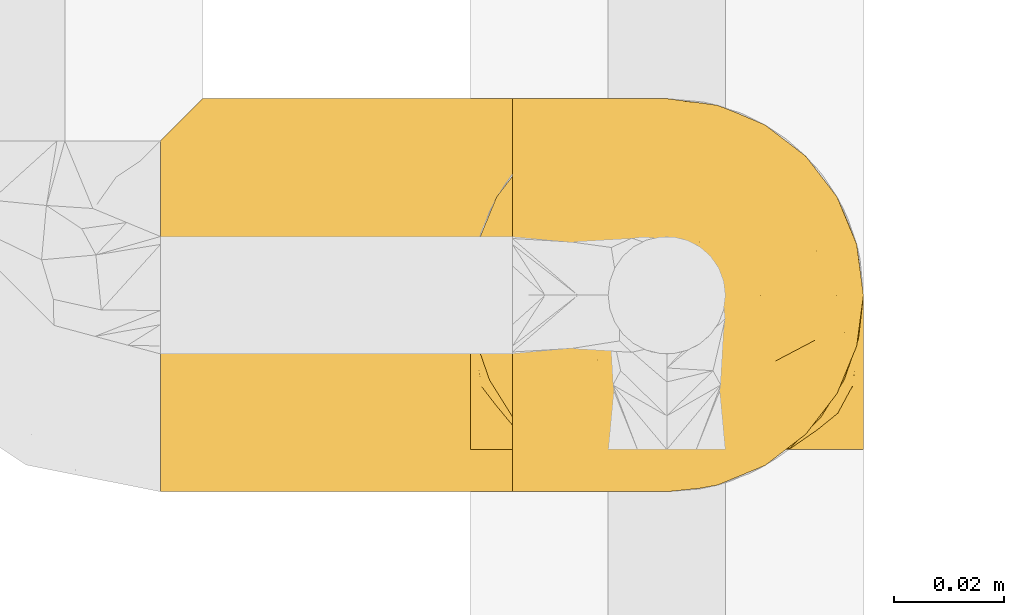
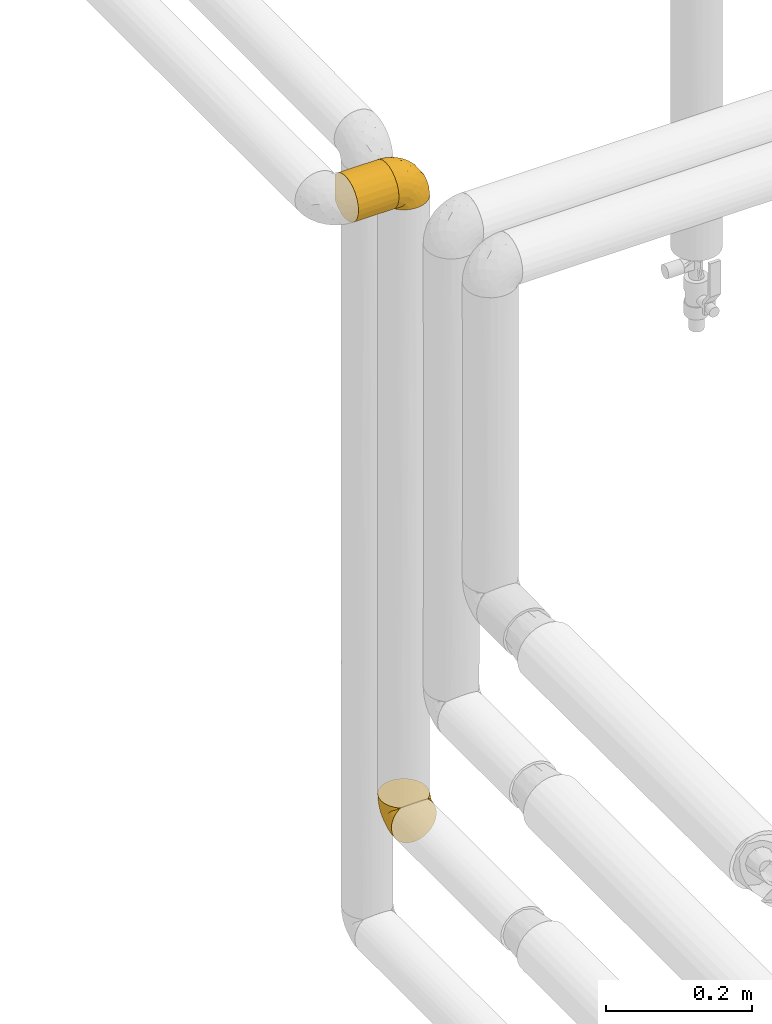
# One storey, part 79 of 827: 3 coverings.
"""IFC2X3 building model written with IfcOpenShell, lengths in millimetres."""

from ifc_helpers import new_model, entity, si_unit, converted_unit, derived_unit, direction, frame, origin, place, context, subcontext, project, spatial, faceted_brep, element, save


model = new_model("IFC2X3")

# Units and contexts
model_context = context("Model", 3, precision=0.01, world=origin(), true_north=direction((6.12303176911189e-17, 1.0)))
body_context = subcontext(model_context, "Body", "Model", "MODEL_VIEW")
ifc_project = project(units=[si_unit("LENGTHUNIT", "METRE", prefix="MILLI"), si_unit("AREAUNIT", "SQUARE_METRE"), si_unit("VOLUMEUNIT", "CUBIC_METRE"), converted_unit("PLANEANGLEUNIT", "DEGREE", entity("IfcRatioMeasure", 0.0174532925199433), si_unit("PLANEANGLEUNIT", "RADIAN"), dimensions=[0, 0, 0, 0, 0, 0, 0]), si_unit("MASSUNIT", "GRAM", prefix="KILO"), derived_unit("MASSDENSITYUNIT", [(si_unit("MASSUNIT", "GRAM", prefix="KILO"), 1), (si_unit("LENGTHUNIT", "METRE"), -3)]), derived_unit("MOMENTOFINERTIAUNIT", [(si_unit("LENGTHUNIT", "METRE"), 4)]), si_unit("TIMEUNIT", "SECOND"), si_unit("FREQUENCYUNIT", "HERTZ"), si_unit("THERMODYNAMICTEMPERATUREUNIT", "DEGREE_CELSIUS"), derived_unit("THERMALTRANSMITTANCEUNIT", [(si_unit("MASSUNIT", "GRAM", prefix="KILO"), 1), (si_unit("THERMODYNAMICTEMPERATUREUNIT", "KELVIN"), -1), (si_unit("TIMEUNIT", "SECOND"), -3)]), derived_unit("VOLUMETRICFLOWRATEUNIT", [(si_unit("LENGTHUNIT", "METRE"), 3), (si_unit("TIMEUNIT", "SECOND"), -1)]), derived_unit("MASSFLOWRATEUNIT", [(si_unit("MASSUNIT", "GRAM", prefix="KILO"), 1), (si_unit("TIMEUNIT", "SECOND"), -1)]), derived_unit("ROTATIONALFREQUENCYUNIT", [(si_unit("TIMEUNIT", "SECOND"), -1)]), si_unit("ELECTRICCURRENTUNIT", "AMPERE"), si_unit("ELECTRICVOLTAGEUNIT", "VOLT"), si_unit("POWERUNIT", "WATT"), si_unit("FORCEUNIT", "NEWTON", prefix="KILO"), si_unit("ILLUMINANCEUNIT", "LUX"), si_unit("LUMINOUSFLUXUNIT", "LUMEN"), si_unit("LUMINOUSINTENSITYUNIT", "CANDELA"), derived_unit("USERDEFINED", [(si_unit("MASSUNIT", "GRAM", prefix="KILO"), -1), (si_unit("LENGTHUNIT", "METRE"), -2), (si_unit("TIMEUNIT", "SECOND"), 3), (si_unit("LUMINOUSFLUXUNIT", "LUMEN"), 1)]), derived_unit("LINEARVELOCITYUNIT", [(si_unit("LENGTHUNIT", "METRE"), 1), (si_unit("TIMEUNIT", "SECOND"), -1)]), si_unit("PRESSUREUNIT", "PASCAL"), derived_unit("USERDEFINED", [(si_unit("LENGTHUNIT", "METRE"), -2), (si_unit("MASSUNIT", "GRAM", prefix="KILO"), 1), (si_unit("TIMEUNIT", "SECOND"), -2)]), derived_unit("LINEARFORCEUNIT", [(si_unit("MASSUNIT", "GRAM", prefix="KILO"), 1), (si_unit("LENGTHUNIT", "METRE"), 1), (si_unit("TIMEUNIT", "SECOND"), -2), (si_unit("LENGTHUNIT", "METRE"), -1)]), derived_unit("PLANARFORCEUNIT", [(si_unit("MASSUNIT", "GRAM", prefix="KILO"), 1), (si_unit("LENGTHUNIT", "METRE"), 1), (si_unit("TIMEUNIT", "SECOND"), -2), (si_unit("LENGTHUNIT", "METRE"), -2)])], contexts=[model_context])

# Site, building, storey
site_placement = place(None, origin())
site = spatial("IfcSite", under=ifc_project, at=site_placement, CompositionType="ELEMENT")
building_placement = place(site_placement, origin())
building = spatial("IfcBuilding", under=site, at=building_placement, CompositionType="ELEMENT")
storey_placement = place(building_placement, frame((0.0, 0.0, 28200.0)))
storey = spatial("IfcBuildingStorey", under=building, at=storey_placement, Name="08", CompositionType="ELEMENT", Elevation=28200.0)

# Coverings
covering_1_placement = place(storey_placement, frame((17889.48, 11966.61, 808.5)))
element("IfcCovering", 1, at=covering_1_placement, inside=storey, Name=":ADSK_", ObjectType=":ADSK_", PredefinedType="INSULATION", context=body_context, shape_type="Brep", body=[
    faceted_brep([(5.13, 1.6, 21.77), (9.38, 1.6, 15.01), (15.02, 1.6, 9.37), (21.78, 1.6, 5.12), (29.32, 1.6, 2.49), (37.25, 1.6, 1.6), (45.18, 1.6, 2.49), (52.72, 1.6, 5.13), (59.48, 1.6, 9.38), (65.12, 1.6, 15.02), (69.37, 1.6, 21.78), (72.0, 1.6, 29.32), (72.9, 1.6, 37.25), (72.01, 1.6, 45.15), (69.39, 1.6, 52.65), (65.18, 1.6, 59.39), (59.59, 1.6, 65.02), (57.53, 1.6, 65.02), (56.06, 1.6, 65.02), (54.3, 1.6, 65.02), (52.53, 1.6, 65.02), (50.77, 1.6, 65.02), (49.0, 1.6, 65.02), (47.24, 1.6, 65.02), (45.47, 1.6, 65.02), (43.71, 1.6, 65.02), (41.94, 1.6, 65.02), (40.18, 1.6, 65.02), (38.41, 1.6, 65.02), (36.65, 1.6, 65.02), (34.88, 1.6, 65.02), (33.12, 1.6, 65.02), (31.35, 1.6, 65.02), (29.3, 1.6, 65.02), (27.24, 1.6, 65.02), (25.18, 1.6, 65.02), (23.13, 1.6, 65.02), (21.07, 1.6, 65.02), (19.01, 1.6, 65.02), (16.96, 1.6, 65.02), (14.9, 1.6, 65.02), (9.3, 1.6, 59.38), (5.09, 1.6, 52.64), (2.48, 1.6, 45.13), (1.6, 1.6, 37.25), (2.49, 1.6, 29.31), (59.59, 1.82, 65.25), (65.19, 7.46, 65.25), (69.4, 14.2, 65.25), (72.01, 21.7, 65.25), (72.9, 29.6, 65.25), (71.68, 38.82, 65.25), (68.12, 47.42, 65.25), (62.45, 54.8, 65.25), (55.07, 60.47, 65.25), (46.47, 64.03, 65.25), (37.25, 65.25, 65.25), (28.02, 64.03, 65.25), (19.42, 60.47, 65.25), (12.04, 54.8, 65.25), (6.37, 47.42, 65.25), (2.81, 38.82, 65.25), (1.6, 29.6, 65.25), (2.48, 21.7, 65.25), (5.09, 14.2, 65.25), (9.3, 7.46, 65.25), (14.9, 1.82, 65.25), (15.93, 1.82, 65.25), (17.69, 1.82, 65.25), (19.09, 1.82, 65.25), (20.49, 1.82, 65.25), (21.88, 1.82, 65.25), (23.28, 1.82, 65.25), (24.68, 1.82, 65.25), (26.07, 1.82, 65.25), (27.47, 1.82, 65.25), (28.87, 1.82, 65.25), (30.26, 1.82, 65.25), (31.66, 1.82, 65.25), (33.06, 1.82, 65.25), (34.45, 1.82, 65.25), (35.85, 1.82, 65.25), (37.25, 1.82, 65.25), (39.01, 1.82, 65.25), (40.77, 1.82, 65.25), (42.54, 1.82, 65.25), (44.3, 1.82, 65.25), (46.07, 1.82, 65.25), (47.83, 1.82, 65.25), (49.6, 1.82, 65.25), (51.36, 1.82, 65.25), (53.42, 1.82, 65.25), (55.48, 1.82, 65.25), (57.53, 1.82, 65.25), (24.13, 1.75, 65.08), (22.58, 1.76, 65.09), (46.76, 1.76, 65.09), (45.43, 1.76, 65.1), (51.49, 1.74, 65.08), (35.2, 1.76, 65.09), (58.19, 1.75, 65.09), (56.8, 1.75, 65.09), (32.4, 1.75, 65.09), (30.96, 1.76, 65.1), (16.26, 1.74, 65.08), (14.9, 1.75, 65.09), (28.17, 1.74, 65.08), (26.81, 1.76, 65.09), (55.49, 1.75, 65.08), (44.1, 1.75, 65.09), (42.83, 1.74, 65.07), (36.55, 1.76, 65.1), (37.92, 1.76, 65.09), (29.48, 1.76, 65.1), (39.3, 1.73, 65.07), (48.12, 1.74, 65.07), (49.39, 1.75, 65.09), (17.58, 1.74, 65.08), (33.81, 1.75, 65.09), (41.72, 1.78, 65.13), (54.15, 1.76, 65.1), (52.82, 1.76, 65.09), (40.57, 1.75, 65.09), (21.1, 1.76, 65.1), (19.79, 1.75, 65.09), (59.59, 1.75, 65.09), (25.46, 1.76, 65.09), (70.91, 13.11, 53.74), (68.25, 8.18, 57.19), (72.9, 25.84, 51.25), (72.9, 28.13, 59.77), (72.9, 15.6, 41.0), (64.57, 5.2, 61.64), (72.9, 20.72, 46.12), (72.9, 7.07, 38.71), (46.9, 35.56, 13.0), (49.02, 16.98, 5.55), (37.25, 25.95, 6.44), (72.16, 35.4, 55.39), (72.12, 32.74, 48.48), (65.96, 43.51, 39.63), (58.95, 53.51, 43.5), (65.53, 49.6, 52.38), (70.18, 40.07, 49.31), (70.18, 42.61, 58.01), (67.43, 20.45, 22.23), (67.43, 10.52, 19.14), (62.46, 14.87, 13.73), (72.19, 24.92, 39.1), (53.36, 34.61, 15.38), (43.86, 61.84, 46.7), (50.89, 60.43, 49.4), (37.25, 14.29, 4.12), (58.95, 57.0, 55.35), (55.84, 42.79, 23.83), (59.19, 33.34, 19.0), (71.35, 21.53, 32.44), (70.9, 11.52, 26.73), (56.22, 12.66, 8.12), (67.42, 34.11, 31.34), (70.63, 32.29, 38.81), (61.45, 24.41, 16.11), (56.22, 24.95, 11.96), (48.22, 44.19, 20.31), (51.43, 56.24, 38.81), (45.24, 56.83, 35.48), (50.08, 50.94, 28.94), (43.45, 50.38, 25.21), (37.25, 46.6, 20.24), (37.25, 36.28, 13.34), (37.25, 62.72, 52.55), (59.41, 47.39, 33.16), (62.46, 38.92, 27.33), (64.67, 29.55, 22.86), (68.35, 26.82, 27.48), (37.25, 60.4, 40.89), (37.25, 53.5, 30.56), (4.31, 41.8, 54.41), (30.45, 61.8, 46.71), (25.32, 49.33, 26.31), (27.59, 35.54, 12.98), (12.04, 14.87, 13.72), (18.28, 12.65, 8.12), (8.96, 47.44, 46.04), (15.54, 56.06, 51.06), (16.32, 50.17, 35.69), (7.06, 20.44, 22.22), (7.06, 10.52, 19.13), (3.6, 11.52, 26.72), (19.36, 38.79, 19.65), (2.28, 33.87, 51.87), (1.6, 25.84, 51.25), (1.6, 27.72, 58.25), (1.6, 7.07, 38.71), (25.07, 62.13, 54.36), (8.96, 50.52, 56.5), (29.08, 56.47, 34.9), (23.6, 58.39, 43.16), (25.48, 16.98, 5.54), (7.69, 39.3, 35.66), (4.1, 38.56, 47.21), (18.28, 24.94, 11.95), (2.18, 30.34, 46.27), (2.39, 26.49, 39.95), (1.6, 15.6, 41.0), (1.6, 20.72, 46.12), (12.04, 26.6, 18.27), (3.15, 21.54, 32.43), (2.24, 35.7, 58.69), (12.04, 38.91, 27.31), (6.5, 30.65, 29.52), (11.64, 44.9, 35.02), (3.92, 34.09, 40.81), (3.58, 13.11, 53.74), (6.24, 9.65, 58.66), (9.92, 5.2, 61.64)], [[[0, 1, 2, 3, 4, 5, 6, 7, 8, 9, 10, 11, 12, 13, 14, 15, 16, 17, 18, 19, 20, 21, 22, 23, 24, 25, 26, 27, 28, 29, 30, 31, 32, 33, 34, 35, 36, 37, 38, 39, 40, 41, 42, 43, 44, 45]], [[46, 47, 48, 49, 50, 51, 52, 53, 54, 55, 56, 57, 58, 59, 60, 61, 62, 63, 64, 65, 66, 67, 68, 69, 70, 71, 72, 73, 74, 75, 76, 77, 78, 79, 80, 81, 82, 83, 84, 85, 86, 87, 88, 89, 90, 91, 92, 93]], [[94, 72, 95]], [[96, 87, 97]], [[20, 98, 21]], [[99, 81, 80]], [[100, 93, 101]], [[102, 103, 32]], [[104, 105, 40]], [[67, 105, 104]], [[106, 107, 34]], [[18, 101, 108]], [[109, 85, 110]], [[36, 94, 95]], [[81, 111, 82]], [[29, 28, 112]], [[17, 101, 18]], [[103, 113, 33]], [[24, 96, 97]], [[28, 114, 112]], [[115, 22, 116]], [[31, 102, 32]], [[68, 104, 117]], [[31, 118, 102]], [[84, 119, 85]], [[120, 91, 121]], [[23, 22, 115]], [[114, 27, 122]], [[123, 37, 95]], [[117, 124, 69]], [[67, 66, 105]], [[104, 39, 117]], [[123, 124, 37]], [[100, 17, 16]], [[100, 125, 46]], [[17, 100, 101]], [[107, 126, 35]], [[92, 108, 101]], [[115, 88, 96]], [[114, 122, 83]], [[101, 93, 92]], [[93, 100, 46]], [[16, 125, 100]], [[108, 19, 18]], [[120, 121, 19]], [[108, 92, 120]], [[19, 108, 120]], [[67, 104, 68]], [[39, 104, 40]], [[69, 68, 117]], [[117, 39, 38]], [[70, 124, 123]], [[124, 70, 69]], [[38, 124, 117]], [[124, 38, 37]], [[72, 71, 95]], [[71, 123, 95]], [[71, 70, 123]], [[126, 94, 35]], [[37, 36, 95]], [[75, 74, 107]], [[73, 72, 94]], [[94, 36, 35]], [[94, 126, 73]], [[74, 73, 126]], [[106, 76, 75]], [[76, 106, 113]], [[113, 106, 33]], [[107, 35, 34]], [[106, 34, 33]], [[126, 107, 74]], [[107, 106, 75]], [[78, 77, 103]], [[77, 113, 103]], [[77, 76, 113]], [[102, 78, 103]], [[33, 32, 103]], [[80, 79, 118]], [[102, 118, 79]], [[112, 111, 29]], [[118, 31, 30]], [[79, 78, 102]], [[99, 111, 81]], [[112, 82, 111]], [[111, 99, 29]], [[30, 29, 99]], [[112, 83, 82]], [[27, 114, 28]], [[99, 118, 30]], [[118, 99, 80]], [[114, 83, 112]], [[84, 83, 122]], [[109, 110, 25]], [[122, 27, 26]], [[119, 110, 85]], [[20, 19, 121]], [[25, 110, 26]], [[91, 120, 92]], [[90, 98, 121]], [[121, 91, 90]], [[23, 115, 96]], [[88, 115, 116]], [[116, 98, 89]], [[89, 88, 116]], [[23, 96, 24]], [[87, 96, 88]], [[25, 24, 109]], [[97, 87, 86]], [[90, 89, 98]], [[116, 22, 21]], [[122, 26, 119]], [[86, 85, 109]], [[109, 97, 86]], [[97, 109, 24]], [[110, 119, 26]], [[122, 119, 84]], [[121, 98, 20]], [[21, 98, 116]], [[48, 127, 49]], [[48, 47, 128]], [[49, 129, 130, 50]], [[129, 49, 127]], [[131, 127, 13]], [[46, 125, 132]], [[16, 15, 132]], [[127, 128, 14]], [[127, 131, 133, 129]], [[14, 13, 127]], [[13, 12, 134, 131]], [[46, 132, 47]], [[48, 128, 127]], [[47, 132, 128]], [[15, 128, 132]], [[125, 16, 132]], [[15, 14, 128]], [[135, 136, 137]], [[138, 129, 139]], [[140, 141, 142]], [[143, 144, 138]], [[145, 146, 147]], [[133, 148, 139]], [[134, 12, 11]], [[136, 135, 149]], [[150, 55, 151]], [[136, 6, 152]], [[153, 54, 53]], [[52, 144, 142]], [[52, 142, 53]], [[54, 153, 151]], [[144, 52, 51]], [[154, 155, 149]], [[156, 131, 157]], [[134, 11, 157]], [[8, 7, 158]], [[147, 9, 8]], [[157, 131, 134]], [[157, 11, 10]], [[146, 157, 10]], [[159, 140, 160]], [[157, 145, 156]], [[161, 162, 155]], [[161, 147, 162]], [[154, 149, 163]], [[150, 164, 165]], [[136, 7, 6]], [[137, 136, 152]], [[162, 158, 136]], [[54, 151, 55]], [[158, 147, 8]], [[166, 167, 165]], [[9, 146, 10]], [[164, 166, 165]], [[168, 135, 137, 169]], [[55, 150, 170]], [[154, 171, 172]], [[139, 148, 160]], [[140, 142, 143]], [[153, 142, 141]], [[51, 50, 130]], [[145, 173, 174]], [[156, 160, 148]], [[6, 5, 152]], [[136, 158, 7]], [[147, 158, 162]], [[147, 146, 9]], [[157, 146, 145]], [[160, 140, 143]], [[140, 172, 171]], [[139, 143, 138]], [[173, 159, 174]], [[170, 150, 175]], [[170, 56, 55]], [[167, 168, 176]], [[176, 175, 165]], [[150, 165, 175]], [[163, 167, 166]], [[176, 165, 167]], [[164, 150, 151]], [[151, 141, 164]], [[171, 164, 141]], [[154, 163, 166]], [[163, 135, 168]], [[166, 164, 171]], [[155, 154, 172]], [[166, 171, 154]], [[140, 171, 141]], [[173, 155, 172]], [[149, 155, 162]], [[159, 173, 172]], [[161, 145, 147]], [[140, 159, 172]], [[174, 160, 156]], [[136, 149, 162]], [[149, 135, 163]], [[155, 173, 161]], [[145, 161, 173]], [[160, 174, 159]], [[156, 148, 131]], [[156, 145, 174]], [[142, 153, 53]], [[151, 153, 141]], [[138, 51, 130]], [[142, 144, 143]], [[51, 138, 144]], [[129, 138, 130]], [[133, 139, 129]], [[160, 143, 139]], [[168, 167, 163]], [[131, 148, 133]], [[60, 177, 61]], [[175, 178, 170]], [[179, 168, 180]], [[178, 57, 170]], [[181, 182, 2]], [[183, 184, 185]], [[186, 187, 188]], [[189, 185, 179]], [[190, 191, 192]], [[45, 193, 188]], [[194, 184, 58]], [[45, 44, 193]], [[59, 195, 60]], [[60, 195, 177]], [[0, 45, 188]], [[196, 179, 197]], [[180, 137, 198]], [[183, 199, 200]], [[201, 182, 181]], [[1, 181, 2]], [[57, 178, 194]], [[198, 3, 182]], [[198, 152, 4]], [[1, 0, 187]], [[190, 202, 191]], [[203, 204, 205]], [[206, 201, 181]], [[186, 188, 207]], [[188, 204, 207]], [[3, 198, 4]], [[58, 184, 59]], [[187, 181, 1]], [[180, 198, 201]], [[206, 181, 186]], [[180, 189, 179]], [[3, 2, 182]], [[180, 168, 169, 137]], [[204, 188, 193]], [[177, 190, 208]], [[209, 210, 199]], [[210, 186, 207]], [[185, 184, 197]], [[195, 184, 183]], [[205, 202, 203]], [[210, 209, 206]], [[179, 185, 197]], [[211, 209, 199]], [[196, 197, 178]], [[180, 201, 189]], [[152, 198, 137]], [[152, 5, 4]], [[61, 208, 62]], [[198, 182, 201]], [[188, 187, 0]], [[181, 187, 186]], [[203, 210, 207]], [[202, 205, 191]], [[199, 210, 212]], [[57, 56, 170]], [[176, 196, 175]], [[178, 197, 194]], [[179, 176, 168]], [[175, 196, 178]], [[176, 179, 196]], [[184, 194, 197]], [[58, 57, 194]], [[208, 190, 192]], [[200, 190, 177]], [[206, 189, 201]], [[185, 189, 209]], [[62, 208, 192]], [[177, 208, 61]], [[210, 206, 186]], [[189, 206, 209]], [[200, 199, 212]], [[211, 183, 185]], [[184, 195, 59]], [[177, 195, 183]], [[183, 200, 177]], [[202, 200, 212]], [[200, 202, 190]], [[202, 212, 203]], [[210, 203, 212]], [[204, 203, 207]], [[183, 211, 199]], [[185, 209, 211]], [[63, 62, 192, 191]], [[64, 63, 213]], [[64, 213, 214]], [[65, 215, 66]], [[213, 191, 205, 204]], [[43, 204, 193, 44]], [[65, 214, 215]], [[42, 213, 43]], [[215, 105, 66]], [[41, 214, 42]], [[40, 105, 215]], [[65, 64, 214]], [[40, 215, 41]], [[213, 63, 191]], [[42, 214, 213]], [[204, 43, 213]], [[214, 41, 215]]]),
])
covering_2_placement = place(storey_placement, frame((17833.3, 11958.96, 1862.75)))
element("IfcCovering", 2, at=covering_2_placement, inside=storey, Name=":ADSK_", ObjectType=":ADSK_", PredefinedType="INSULATION", context=body_context, shape_type="Brep", body=[
    faceted_brep([(65.43, 71.99, 29.26), (65.43, 72.9, 37.25), (65.43, 71.68, 46.47), (65.43, 68.12, 55.07), (65.43, 62.45, 62.45), (65.43, 55.07, 68.12), (65.43, 46.47, 71.68), (65.43, 37.25, 72.9), (65.43, 28.02, 71.68), (65.43, 19.42, 68.12), (65.43, 12.04, 62.45), (65.43, 6.37, 55.07), (65.43, 2.81, 46.47), (65.43, 1.6, 37.25), (65.43, 2.5, 29.26), (65.43, 5.17, 21.68), (65.43, 9.47, 14.89), (65.43, 15.18, 9.25), (65.43, 59.31, 9.25), (65.43, 65.02, 14.89), (65.43, 69.32, 21.68), (1.6, 65.25, 15.18), (1.6, 59.6, 9.47), (1.6, 52.81, 5.17), (1.6, 45.24, 2.5), (1.6, 37.25, 1.6), (1.6, 28.02, 2.81), (1.6, 19.42, 6.37), (1.6, 12.04, 12.04), (1.6, 6.37, 19.42), (1.6, 2.81, 28.02), (1.6, 1.6, 37.25), (1.6, 2.81, 46.47), (1.6, 6.37, 55.07), (1.6, 12.04, 62.45), (1.6, 19.42, 68.12), (1.6, 28.02, 71.68), (1.6, 37.25, 72.9), (1.6, 45.24, 71.99), (1.6, 52.81, 69.32), (1.6, 59.6, 65.02), (1.6, 65.25, 59.31), (59.74, 25.57, 3.56), (58.27, 31.32, 2.09), (57.78, 37.25, 1.6), (62.15, 20.14, 5.97), (58.27, 43.17, 2.09), (59.74, 48.92, 3.56), (62.15, 54.35, 5.97), (4.87, 68.52, 20.14), (7.28, 70.93, 25.57), (8.75, 72.4, 31.32), (9.25, 72.9, 37.25), (8.75, 72.4, 43.17), (7.28, 70.93, 48.92), (4.87, 68.52, 54.35)], [[[0, 1, 2, 3, 4, 5, 6, 7, 8, 9, 10, 11, 12, 13, 14, 15, 16, 17, 18, 19, 20]], [[21, 22, 23, 24, 25, 26, 27, 28, 29, 30, 31, 32, 33, 34, 35, 36, 37, 38, 39, 40, 41]], [[31, 30, 14]], [[29, 28, 16]], [[30, 29, 15]], [[13, 31, 14]], [[16, 15, 29]], [[30, 15, 14]], [[28, 17, 16]], [[42, 27, 26]], [[26, 25, 43]], [[44, 43, 25]], [[45, 17, 27]], [[43, 42, 26]], [[45, 27, 42]], [[27, 17, 28]], [[46, 25, 24]], [[47, 24, 23]], [[48, 23, 22]], [[46, 44, 25]], [[48, 47, 23]], [[18, 48, 22]], [[46, 24, 47]], [[22, 19, 18]], [[21, 49, 19]], [[50, 51, 0]], [[49, 50, 20]], [[19, 49, 20]], [[51, 1, 0]], [[0, 20, 50]], [[1, 51, 52]], [[21, 19, 22]], [[53, 54, 2]], [[55, 41, 3]], [[54, 55, 3]], [[52, 53, 1]], [[1, 53, 2]], [[54, 3, 2]], [[41, 4, 3]], [[5, 40, 39]], [[6, 39, 38]], [[7, 38, 37]], [[4, 40, 5]], [[5, 39, 6]], [[38, 7, 6]], [[40, 4, 41]], [[8, 7, 37, 36]], [[9, 8, 36, 35]], [[35, 34, 10, 9]], [[12, 11, 33, 32]], [[13, 12, 32, 31]], [[34, 33, 11, 10]], [[46, 47, 48, 18, 17, 45, 42, 43, 44]], [[41, 55, 54, 53, 52, 51, 50, 49, 21]]]),
])
covering_3_placement = place(storey_placement, frame((17897.13, 11958.96, 1870.4)))
element("IfcCovering", 3, at=covering_3_placement, inside=storey, Name=":ADSK_", ObjectType=":ADSK_", PredefinedType="INSULATION", context=body_context, shape_type="Brep", body=[
    faceted_brep([(1.6, 5.13, 45.07), (1.6, 9.38, 51.83), (1.6, 15.02, 57.47), (1.6, 21.78, 61.72), (1.6, 29.32, 64.35), (1.6, 37.25, 65.25), (1.6, 45.18, 64.35), (1.6, 52.72, 61.71), (1.6, 59.48, 57.46), (1.6, 65.12, 51.82), (1.6, 69.37, 45.06), (1.6, 72.0, 37.52), (1.6, 72.9, 29.6), (1.6, 72.01, 21.69), (1.6, 69.39, 14.19), (1.6, 65.18, 7.45), (1.6, 59.59, 1.82), (1.6, 57.53, 1.82), (1.6, 56.06, 1.82), (1.6, 54.3, 1.82), (1.6, 52.53, 1.82), (1.6, 50.77, 1.82), (1.6, 49.0, 1.82), (1.6, 47.24, 1.82), (1.6, 45.47, 1.82), (1.6, 43.71, 1.82), (1.6, 41.94, 1.82), (1.6, 40.18, 1.82), (1.6, 38.41, 1.82), (1.6, 36.65, 1.82), (1.6, 34.88, 1.82), (1.6, 33.12, 1.82), (1.6, 31.35, 1.82), (1.6, 29.3, 1.82), (1.6, 27.24, 1.82), (1.6, 25.18, 1.82), (1.6, 23.13, 1.82), (1.6, 21.07, 1.82), (1.6, 19.01, 1.82), (1.6, 16.96, 1.82), (1.6, 14.9, 1.82), (1.6, 9.3, 7.46), (1.6, 5.09, 14.2), (1.6, 2.48, 21.71), (1.6, 1.6, 29.6), (1.6, 2.49, 37.53), (1.82, 59.59, 1.6), (7.46, 65.19, 1.6), (14.2, 69.4, 1.6), (21.7, 72.01, 1.6), (29.6, 72.9, 1.6), (38.82, 71.68, 1.6), (47.42, 68.12, 1.6), (54.8, 62.45, 1.6), (60.47, 55.07, 1.6), (64.03, 46.47, 1.6), (65.25, 37.25, 1.6), (64.03, 28.02, 1.6), (60.47, 19.42, 1.6), (54.8, 12.04, 1.6), (47.42, 6.37, 1.6), (38.82, 2.81, 1.6), (29.6, 1.6, 1.6), (21.7, 2.48, 1.6), (14.2, 5.09, 1.6), (7.46, 9.3, 1.6), (1.82, 14.9, 1.6), (1.82, 15.93, 1.6), (1.82, 17.69, 1.6), (1.82, 19.09, 1.6), (1.82, 20.49, 1.6), (1.82, 21.88, 1.6), (1.82, 23.28, 1.6), (1.82, 24.68, 1.6), (1.82, 26.07, 1.6), (1.82, 27.47, 1.6), (1.82, 28.87, 1.6), (1.82, 30.26, 1.6), (1.82, 31.66, 1.6), (1.82, 33.06, 1.6), (1.82, 34.45, 1.6), (1.82, 35.85, 1.6), (1.82, 37.25, 1.6), (1.82, 39.01, 1.6), (1.82, 40.77, 1.6), (1.82, 42.54, 1.6), (1.82, 44.3, 1.6), (1.82, 46.07, 1.6), (1.82, 47.83, 1.6), (1.82, 49.6, 1.6), (1.82, 51.36, 1.6), (1.82, 53.42, 1.6), (1.82, 55.48, 1.6), (1.82, 57.53, 1.6), (1.75, 24.13, 1.76), (1.76, 22.58, 1.75), (1.76, 46.76, 1.75), (1.76, 45.43, 1.74), (1.74, 51.49, 1.76), (1.76, 35.2, 1.75), (1.75, 58.19, 1.75), (1.75, 56.8, 1.75), (1.75, 32.4, 1.75), (1.76, 30.96, 1.75), (1.74, 16.26, 1.76), (1.75, 14.9, 1.75), (1.74, 28.17, 1.76), (1.76, 26.81, 1.75), (1.75, 55.49, 1.76), (1.75, 44.1, 1.75), (1.74, 42.83, 1.77), (1.76, 36.55, 1.74), (1.76, 37.92, 1.75), (1.76, 29.48, 1.75), (1.73, 39.3, 1.77), (1.74, 48.12, 1.77), (1.75, 49.39, 1.75), (1.74, 17.58, 1.76), (1.75, 33.81, 1.75), (1.78, 41.72, 1.71), (1.76, 54.15, 1.74), (1.76, 52.82, 1.75), (1.75, 40.57, 1.75), (1.76, 21.1, 1.74), (1.75, 19.79, 1.75), (1.75, 59.59, 1.75), (1.76, 25.46, 1.75), (13.11, 70.91, 13.1), (8.18, 68.25, 9.65), (25.84, 72.9, 15.6), (28.13, 72.9, 7.07), (15.6, 72.9, 25.84), (5.2, 64.57, 5.2), (20.72, 72.9, 20.72), (7.07, 72.9, 28.13), (35.56, 46.9, 53.84), (16.98, 49.02, 61.29), (25.95, 37.25, 60.4), (35.4, 72.16, 11.45), (32.74, 72.12, 18.37), (43.51, 65.96, 27.21), (53.51, 58.95, 23.34), (49.6, 65.53, 14.46), (40.07, 70.18, 17.53), (42.61, 70.18, 8.83), (20.45, 67.43, 44.61), (10.52, 67.43, 47.7), (14.87, 62.46, 53.12), (24.92, 72.19, 27.74), (34.61, 53.36, 51.46), (61.84, 43.86, 20.14), (60.43, 50.89, 17.44), (14.29, 37.25, 62.72), (57.0, 58.95, 11.49), (42.79, 55.84, 43.01), (33.34, 59.19, 47.84), (21.53, 71.35, 34.4), (11.52, 70.9, 40.11), (12.66, 56.22, 58.72), (34.11, 67.42, 35.5), (32.29, 70.63, 28.03), (24.41, 61.45, 50.73), (24.95, 56.22, 54.88), (44.19, 48.22, 46.53), (56.24, 51.43, 28.03), (56.83, 45.24, 31.36), (50.94, 50.08, 37.9), (50.38, 43.45, 41.63), (46.6, 37.25, 46.6), (36.28, 37.25, 53.5), (62.72, 37.25, 14.29), (47.39, 59.41, 33.68), (38.92, 62.46, 39.51), (29.55, 64.67, 43.98), (26.82, 68.35, 39.36), (60.4, 37.25, 25.95), (53.5, 37.25, 36.28), (41.8, 4.31, 12.43), (61.8, 30.45, 20.13), (49.33, 25.32, 40.53), (35.54, 27.59, 53.86), (14.87, 12.04, 53.13), (12.65, 18.28, 58.72), (47.44, 8.96, 20.81), (56.06, 15.54, 15.78), (50.17, 16.32, 31.15), (20.44, 7.06, 44.62), (10.52, 7.06, 47.71), (11.52, 3.6, 40.12), (38.79, 19.36, 47.19), (33.87, 2.28, 14.97), (25.84, 1.6, 15.6), (27.72, 1.6, 8.6), (7.07, 1.6, 28.13), (62.13, 25.07, 12.48), (50.52, 8.96, 10.34), (56.47, 29.08, 31.94), (58.39, 23.6, 23.68), (16.98, 25.48, 61.3), (39.3, 7.69, 31.18), (38.56, 4.1, 19.63), (24.94, 18.28, 54.89), (30.34, 2.18, 20.57), (26.49, 2.39, 26.89), (15.6, 1.6, 25.84), (20.72, 1.6, 20.72), (26.6, 12.04, 48.57), (21.54, 3.15, 34.41), (35.7, 2.24, 8.15), (38.91, 12.04, 39.53), (30.65, 6.5, 37.32), (44.9, 11.64, 31.82), (34.09, 3.92, 26.03), (13.11, 3.58, 13.1), (9.65, 6.24, 8.18), (5.2, 9.92, 5.2)], [[[0, 1, 2, 3, 4, 5, 6, 7, 8, 9, 10, 11, 12, 13, 14, 15, 16, 17, 18, 19, 20, 21, 22, 23, 24, 25, 26, 27, 28, 29, 30, 31, 32, 33, 34, 35, 36, 37, 38, 39, 40, 41, 42, 43, 44, 45]], [[46, 47, 48, 49, 50, 51, 52, 53, 54, 55, 56, 57, 58, 59, 60, 61, 62, 63, 64, 65, 66, 67, 68, 69, 70, 71, 72, 73, 74, 75, 76, 77, 78, 79, 80, 81, 82, 83, 84, 85, 86, 87, 88, 89, 90, 91, 92, 93]], [[94, 72, 95]], [[96, 87, 97]], [[20, 98, 21]], [[99, 81, 80]], [[100, 93, 101]], [[102, 103, 32]], [[104, 105, 40]], [[67, 105, 104]], [[106, 107, 34]], [[18, 101, 108]], [[109, 85, 110]], [[36, 94, 95]], [[81, 111, 82]], [[29, 28, 112]], [[17, 101, 18]], [[103, 113, 33]], [[24, 96, 97]], [[28, 114, 112]], [[115, 22, 116]], [[31, 102, 32]], [[68, 104, 117]], [[31, 118, 102]], [[84, 119, 85]], [[120, 91, 121]], [[23, 22, 115]], [[114, 27, 122]], [[123, 37, 95]], [[117, 124, 69]], [[67, 66, 105]], [[104, 39, 117]], [[123, 124, 37]], [[100, 17, 16]], [[100, 125, 46]], [[17, 100, 101]], [[107, 126, 35]], [[92, 108, 101]], [[115, 88, 96]], [[114, 122, 83]], [[101, 93, 92]], [[93, 100, 46]], [[16, 125, 100]], [[108, 19, 18]], [[120, 121, 19]], [[108, 92, 120]], [[19, 108, 120]], [[67, 104, 68]], [[39, 104, 40]], [[69, 68, 117]], [[117, 39, 38]], [[70, 124, 123]], [[124, 70, 69]], [[38, 124, 117]], [[124, 38, 37]], [[72, 71, 95]], [[71, 123, 95]], [[71, 70, 123]], [[126, 94, 35]], [[37, 36, 95]], [[75, 74, 107]], [[73, 72, 94]], [[94, 36, 35]], [[94, 126, 73]], [[74, 73, 126]], [[106, 76, 75]], [[76, 106, 113]], [[113, 106, 33]], [[107, 35, 34]], [[106, 34, 33]], [[126, 107, 74]], [[107, 106, 75]], [[78, 77, 103]], [[77, 113, 103]], [[77, 76, 113]], [[102, 78, 103]], [[33, 32, 103]], [[80, 79, 118]], [[102, 118, 79]], [[112, 111, 29]], [[118, 31, 30]], [[79, 78, 102]], [[99, 111, 81]], [[112, 82, 111]], [[111, 99, 29]], [[30, 29, 99]], [[112, 83, 82]], [[27, 114, 28]], [[99, 118, 30]], [[118, 99, 80]], [[114, 83, 112]], [[84, 83, 122]], [[109, 110, 25]], [[122, 27, 26]], [[119, 110, 85]], [[20, 19, 121]], [[25, 110, 26]], [[91, 120, 92]], [[90, 98, 121]], [[121, 91, 90]], [[23, 115, 96]], [[88, 115, 116]], [[116, 98, 89]], [[89, 88, 116]], [[23, 96, 24]], [[87, 96, 88]], [[25, 24, 109]], [[97, 87, 86]], [[90, 89, 98]], [[116, 22, 21]], [[122, 26, 119]], [[86, 85, 109]], [[109, 97, 86]], [[97, 109, 24]], [[110, 119, 26]], [[122, 119, 84]], [[121, 98, 20]], [[21, 98, 116]], [[48, 127, 49]], [[48, 47, 128]], [[49, 129, 130, 50]], [[129, 49, 127]], [[131, 127, 13]], [[46, 125, 132]], [[16, 15, 132]], [[127, 128, 14]], [[127, 131, 133, 129]], [[14, 13, 127]], [[13, 12, 134, 131]], [[46, 132, 47]], [[48, 128, 127]], [[47, 132, 128]], [[15, 128, 132]], [[125, 16, 132]], [[15, 14, 128]], [[135, 136, 137]], [[138, 129, 139]], [[140, 141, 142]], [[143, 144, 138]], [[145, 146, 147]], [[133, 148, 139]], [[134, 12, 11]], [[136, 135, 149]], [[150, 55, 151]], [[136, 6, 152]], [[153, 54, 53]], [[52, 144, 142]], [[52, 142, 53]], [[54, 153, 151]], [[144, 52, 51]], [[154, 155, 149]], [[156, 131, 157]], [[134, 11, 157]], [[8, 7, 158]], [[147, 9, 8]], [[157, 131, 134]], [[157, 11, 10]], [[146, 157, 10]], [[159, 140, 160]], [[157, 145, 156]], [[161, 162, 155]], [[161, 147, 162]], [[154, 149, 163]], [[150, 164, 165]], [[136, 7, 6]], [[137, 136, 152]], [[162, 158, 136]], [[54, 151, 55]], [[158, 147, 8]], [[166, 167, 165]], [[9, 146, 10]], [[164, 166, 165]], [[168, 135, 137, 169]], [[55, 150, 170]], [[154, 171, 172]], [[139, 148, 160]], [[140, 142, 143]], [[153, 142, 141]], [[51, 50, 130]], [[145, 173, 174]], [[156, 160, 148]], [[6, 5, 152]], [[136, 158, 7]], [[147, 158, 162]], [[147, 146, 9]], [[157, 146, 145]], [[160, 140, 143]], [[140, 172, 171]], [[139, 143, 138]], [[173, 159, 174]], [[170, 150, 175]], [[170, 56, 55]], [[167, 168, 176]], [[176, 175, 165]], [[150, 165, 175]], [[163, 167, 166]], [[176, 165, 167]], [[164, 150, 151]], [[151, 141, 164]], [[171, 164, 141]], [[154, 163, 166]], [[163, 135, 168]], [[166, 164, 171]], [[155, 154, 172]], [[166, 171, 154]], [[140, 171, 141]], [[173, 155, 172]], [[149, 155, 162]], [[159, 173, 172]], [[161, 145, 147]], [[140, 159, 172]], [[174, 160, 156]], [[136, 149, 162]], [[149, 135, 163]], [[155, 173, 161]], [[145, 161, 173]], [[160, 174, 159]], [[156, 148, 131]], [[156, 145, 174]], [[142, 153, 53]], [[151, 153, 141]], [[138, 51, 130]], [[142, 144, 143]], [[51, 138, 144]], [[129, 138, 130]], [[133, 139, 129]], [[160, 143, 139]], [[168, 167, 163]], [[131, 148, 133]], [[60, 177, 61]], [[175, 178, 170]], [[179, 168, 180]], [[178, 57, 170]], [[181, 182, 2]], [[183, 184, 185]], [[186, 187, 188]], [[189, 185, 179]], [[190, 191, 192]], [[45, 193, 188]], [[194, 184, 58]], [[45, 44, 193]], [[59, 195, 60]], [[60, 195, 177]], [[0, 45, 188]], [[196, 179, 197]], [[180, 137, 198]], [[183, 199, 200]], [[201, 182, 181]], [[1, 181, 2]], [[57, 178, 194]], [[198, 3, 182]], [[198, 152, 4]], [[1, 0, 187]], [[190, 202, 191]], [[203, 204, 205]], [[206, 201, 181]], [[186, 188, 207]], [[188, 204, 207]], [[3, 198, 4]], [[58, 184, 59]], [[187, 181, 1]], [[180, 198, 201]], [[206, 181, 186]], [[180, 189, 179]], [[3, 2, 182]], [[180, 168, 169, 137]], [[204, 188, 193]], [[177, 190, 208]], [[209, 210, 199]], [[210, 186, 207]], [[185, 184, 197]], [[195, 184, 183]], [[205, 202, 203]], [[210, 209, 206]], [[179, 185, 197]], [[211, 209, 199]], [[196, 197, 178]], [[180, 201, 189]], [[152, 198, 137]], [[152, 5, 4]], [[61, 208, 62]], [[198, 182, 201]], [[188, 187, 0]], [[181, 187, 186]], [[203, 210, 207]], [[202, 205, 191]], [[199, 210, 212]], [[57, 56, 170]], [[176, 196, 175]], [[178, 197, 194]], [[179, 176, 168]], [[175, 196, 178]], [[176, 179, 196]], [[184, 194, 197]], [[58, 57, 194]], [[208, 190, 192]], [[200, 190, 177]], [[206, 189, 201]], [[185, 189, 209]], [[62, 208, 192]], [[177, 208, 61]], [[210, 206, 186]], [[189, 206, 209]], [[200, 199, 212]], [[211, 183, 185]], [[184, 195, 59]], [[177, 195, 183]], [[183, 200, 177]], [[202, 200, 212]], [[200, 202, 190]], [[202, 212, 203]], [[210, 203, 212]], [[204, 203, 207]], [[183, 211, 199]], [[185, 209, 211]], [[63, 62, 192, 191]], [[64, 63, 213]], [[64, 213, 214]], [[65, 215, 66]], [[213, 191, 205, 204]], [[43, 204, 193, 44]], [[65, 214, 215]], [[42, 213, 43]], [[215, 105, 66]], [[41, 214, 42]], [[40, 105, 215]], [[65, 64, 214]], [[40, 215, 41]], [[213, 63, 191]], [[42, 214, 213]], [[204, 43, 213]], [[214, 41, 215]]]),
])

save(model, "model.ifc")
